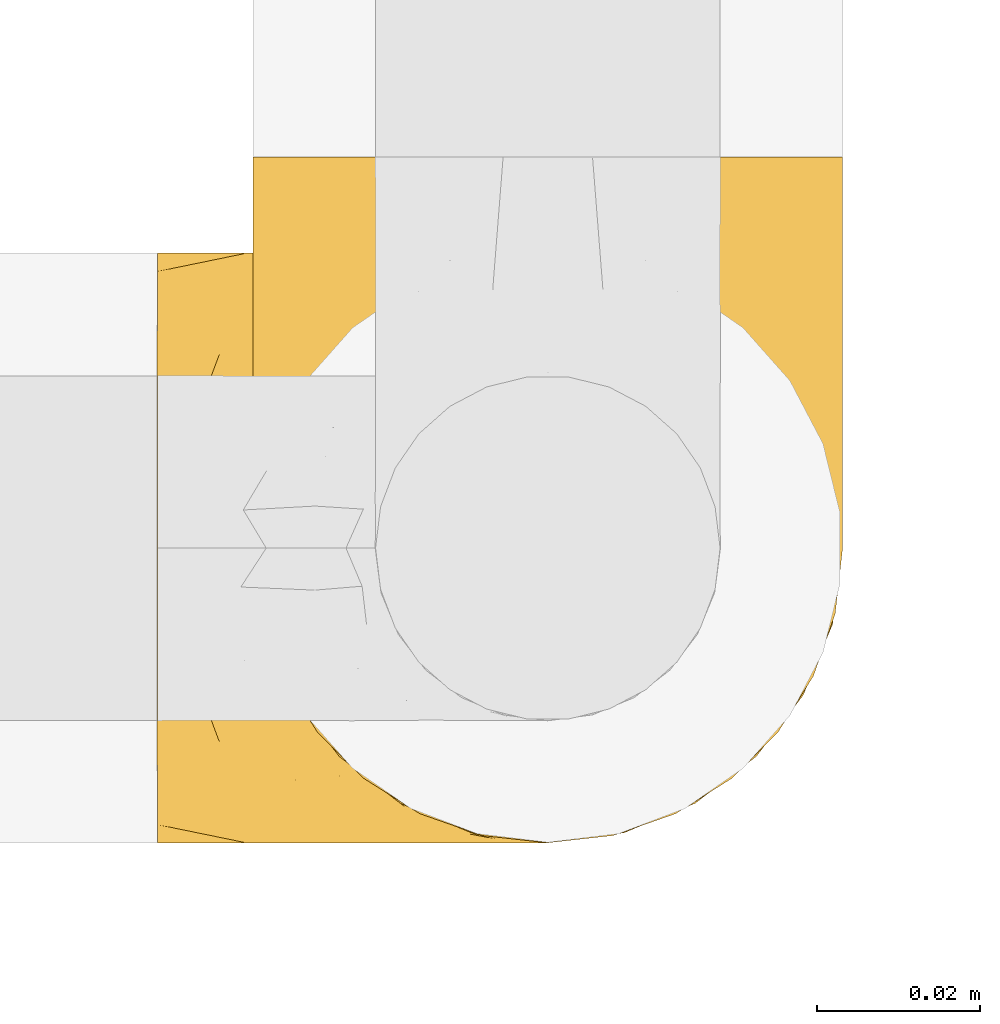
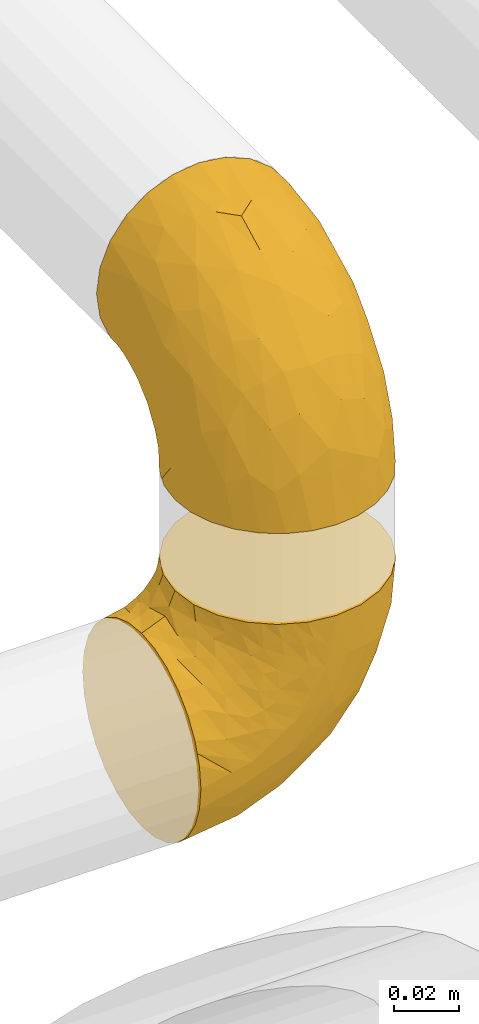
# One storey, part 17 of 39: 2 coverings.
"""IFC2X3 building model written with IfcOpenShell, lengths in millimetres."""

import ifcopenshell
import ifcopenshell.guid

model = None  # the IFC model being written
_history = None  # IfcOwnerHistory: only IFC2X3 demands one
_inside = {}  # id of a spatial element -> (the spatial element, [elements in it])
_under = {}  # id of a project, library or spatial element -> (it, [spatial elements below it])
_declared = {}  # id of a project -> (the project, [libraries it declares])
_typed = {}  # id of a type object -> (the type object, [elements of that type])
_made_of = {}  # id of a material, layer set ... -> (it, [elements and type objects made of it])


def new_model(schema):
    """Start an empty IFC model of exactly this schema.

    Asked for "IFC4X3", IfcOpenShell would pick the latest addendum, in which some entities
    have other attributes; the version numbers below select the first issue.
    IFC2X3 requires an IfcOwnerHistory on every rooted entity: one is made here for all.
    """
    global model, _history
    if schema == "IFC4X3":
        model = ifcopenshell.file(schema_version=(4, 3, 0, 0))
    else:
        model = ifcopenshell.file(schema=schema)
    _inside.clear()
    _under.clear()
    _declared.clear()
    _typed.clear()
    _made_of.clear()
    _history = None
    if model.schema == "IFC2X3":
        org = make("IfcOrganization", Name="unknown")
        user = make(
            "IfcPersonAndOrganization",
            ThePerson=make("IfcPerson", FamilyName="unknown"),
            TheOrganization=org,
        )
        app = make(
            "IfcApplication",
            ApplicationDeveloper=org,
            Version="unknown",
            ApplicationFullName="unknown",
            ApplicationIdentifier="unknown",
        )
        _history = make(
            "IfcOwnerHistory",
            OwningUser=user,
            OwningApplication=app,
            ChangeAction="ADDED",
            CreationDate=0,
        )
    return model


def make(cls, **values):
    """One entity of the class cls with the attributes given. An attribute that is None is left unset."""
    return model.create_entity(
        cls, **{name: value for name, value in values.items() if value is not None}
    )


def entity(cls, *values):
    """Any entity or typed value of the class cls, its attributes in the order of the schema. None: left unset."""
    e = model.create_entity(cls)
    for i, value in enumerate(values):
        if value is not None:
            e[i] = value
    return e


def rooted(cls, **values):
    """An entity with a GlobalId (a new one), such as an element, a storey or a relation."""
    return make(cls, GlobalId=ifcopenshell.guid.new(), OwnerHistory=_history, **values)


def si_unit(unit_type, name, prefix=None):
    """IfcSIUnit, for example si_unit("LENGTHUNIT", "METRE", prefix="MILLI")."""
    return make("IfcSIUnit", UnitType=unit_type, Prefix=prefix, Name=name)


def converted_unit(unit_type, name, factor, base, dimensions=None, offset=None):
    """IfcConversionBasedUnit, such as the inch: factor (a typed value) times the base unit."""
    return make(
        "IfcConversionBasedUnit"
        if offset is None
        else "IfcConversionBasedUnitWithOffset",
        ConversionOffset=offset,
        Dimensions=None
        if dimensions is None
        else entity("IfcDimensionalExponents", *dimensions),
        UnitType=unit_type,
        Name=name,
        ConversionFactor=make(
            "IfcMeasureWithUnit", ValueComponent=factor, UnitComponent=base
        ),
    )


def derived_unit(unit_type, elements):
    """IfcDerivedUnit: a product of units, each with its exponent."""
    return make(
        "IfcDerivedUnit",
        Elements=[
            make("IfcDerivedUnitElement", Unit=unit, Exponent=power)
            for unit, power in elements
        ],
        UnitType=unit_type,
    )


def assignment(units):
    """IfcUnitAssignment: the units of a project."""
    return None if units is None else make("IfcUnitAssignment", Units=units)


def point(xyz):
    """IfcCartesianPoint."""
    return None if xyz is None else make("IfcCartesianPoint", Coordinates=xyz)


def direction(xyz):
    """IfcDirection."""
    return None if xyz is None else make("IfcDirection", DirectionRatios=xyz)


def frame(location, z_axis=None, x_axis=None):
    """IfcAxis2Placement3D, a coordinate frame: its origin and axes. An axis left out is left unset."""
    return make(
        "IfcAxis2Placement3D",
        Location=point(location),
        Axis=direction(z_axis),
        RefDirection=direction(x_axis),
    )


def origin():
    """The frame at (0, 0, 0) with its axes left unset."""
    return frame((0.0, 0.0, 0.0))


def place(relative_to, where):
    """IfcLocalPlacement: puts the frame where relative to a parent placement (None: the world)."""
    return make(
        "IfcLocalPlacement", PlacementRelTo=relative_to, RelativePlacement=where
    )


def context(
    kind, dimensions, precision=None, world=None, true_north=None, identifier=None
):
    """IfcGeometricRepresentationContext, for example the 3D "Model" context."""
    return make(
        "IfcGeometricRepresentationContext",
        ContextIdentifier=identifier,
        ContextType=kind,
        CoordinateSpaceDimension=dimensions,
        Precision=precision,
        WorldCoordinateSystem=world,
        TrueNorth=true_north,
    )


def subcontext(parent, identifier, kind, view, scale=None):
    """IfcGeometricRepresentationSubContext, for example "Body" below "Model"."""
    return make(
        "IfcGeometricRepresentationSubContext",
        ContextIdentifier=identifier,
        ContextType=kind,
        ParentContext=parent,
        TargetScale=scale,
        TargetView=view,
    )


def project(units=None, contexts=None):
    """IfcProject with its units and contexts."""
    return rooted(
        "IfcProject",
        Name="project",
        RepresentationContexts=contexts,
        UnitsInContext=assignment(units),
    )


def spatial(cls, under=None, at=None, **own):
    """A site, building, storey or space (cls), placed at a placement, below another one or the project."""
    s = rooted(cls, ObjectPlacement=at, **own)
    if under is not None:
        _under.setdefault(under.id(), (under, []))[1].append(s)
    return s


def faces_of(points, faces, orient=None, outer=None):
    """IfcFace entities. A face is a list of loops; a loop is a list of indices into points, from 0.

    orient and outer hold one flag for each loop. By default every Orientation is true, the
    first loop of a face is its IfcFaceOuterBound and the others are IfcFaceBound.
    """
    made = []
    for i, loops in enumerate(faces):
        bounds = []
        for j, loop in enumerate(loops):
            is_outer = j == 0 if outer is None else outer[i][j]
            bounds.append(
                make(
                    "IfcFaceOuterBound" if is_outer else "IfcFaceBound",
                    Bound=make("IfcPolyLoop", Polygon=[points[k] for k in loop]),
                    Orientation=True if orient is None else orient[i][j],
                )
            )
        made.append(make("IfcFace", Bounds=bounds))
    return made


def faceted_brep(points, faces, orient=None, outer=None, voids=None):
    """IfcFacetedBrep: a solid bounded by flat faces; with voids (closed shells), ...WithVoids."""
    shared = [point(p) for p in points]
    hull = make("IfcClosedShell", CfsFaces=faces_of(shared, faces, orient, outer))
    if voids is None:
        return make("IfcFacetedBrep", Outer=hull)
    return make(
        "IfcFacetedBrepWithVoids",
        Outer=hull,
        Voids=[
            make(cls, CfsFaces=faces_of(shared, fs, o, b)) for cls, fs, o, b in voids
        ],
    )


def shape(context_of_items, identifier, shape_type, items):
    """IfcShapeRepresentation: the items that make up one representation, for example the "Body"."""
    return make(
        "IfcShapeRepresentation",
        ContextOfItems=context_of_items,
        RepresentationIdentifier=identifier,
        RepresentationType=shape_type,
        Items=items,
    )


def made_of(thing, what):
    """Note that an element or type object is made of a material, layer set ...; save() writes the relation."""
    if what is not None:
        _made_of.setdefault(what.id(), (what, []))[1].append(thing)
    return thing


def element(
    cls,
    number,
    at=None,
    inside=None,
    cuts=None,
    type_object=None,
    material=None,
    context=None,
    identifier="Body",
    shape_type=None,
    held_by="IfcProductDefinitionShape",
    body=None,
    shapes=None,
    **own,
):
    """One element of the class cls, such as IfcWall. Its Tag is "e" and its number.

    at: its placement. inside: the storey or other place that contains it. cuts: it is an
    opening in that element (IfcRelVoidsElement). A single representation is given by context,
    identifier, shape_type and body (its items); several are given by shapes. held_by: the class
    of the entity that holds the representations. save() writes the other relations.
    """
    e = rooted(cls, Tag="e%d" % number, ObjectPlacement=at, **own)
    if body is not None:
        shapes = [shape(context, identifier, shape_type, body)]
    if shapes is not None:
        e.Representation = make(held_by, Representations=shapes)
    if inside is not None:
        _inside.setdefault(inside.id(), (inside, []))[1].append(e)
    if cuts is not None:
        rooted(
            "IfcRelVoidsElement", RelatingBuildingElement=cuts, RelatedOpeningElement=e
        )
    if type_object is not None:
        _typed.setdefault(type_object.id(), (type_object, []))[1].append(e)
    return made_of(e, material)


def aggregate(whole, parts):
    """IfcRelAggregates: a whole, such as a stair, and the parts it consists of."""
    return rooted("IfcRelAggregates", RelatingObject=whole, RelatedObjects=parts)


def save(model, path):
    """Write the relations noted so far, then the file.

    IfcRelAggregates (storeys below a building ...), IfcRelContainedInSpatialStructure (elements
    in a storey), IfcRelDefinesByType, IfcRelAssociatesMaterial and IfcRelDeclares: one each for
    every whole, place, type object, material and project.
    """
    for whole, parts in _under.values():
        aggregate(whole, parts)
    for where, things in _inside.values():
        rooted(
            "IfcRelContainedInSpatialStructure",
            RelatedElements=things,
            RelatingStructure=where,
        )
    for kind, things in _typed.values():
        rooted("IfcRelDefinesByType", RelatedObjects=things, RelatingType=kind)
    for what, things in _made_of.values():
        rooted("IfcRelAssociatesMaterial", RelatedObjects=things, RelatingMaterial=what)
    for by, libraries in _declared.values():
        rooted("IfcRelDeclares", RelatingContext=by, RelatedDefinitions=libraries)
    model.write(path)


model = new_model("IFC2X3")

# Units and contexts
model_context = context("Model", 3, precision=0.01, world=origin(), true_north=direction((6.12303176911189e-17, 1.0)))
body_context = subcontext(model_context, "Body", "Model", "MODEL_VIEW")
ifc_project = project(units=[si_unit("LENGTHUNIT", "METRE", prefix="MILLI"), si_unit("AREAUNIT", "SQUARE_METRE"), si_unit("VOLUMEUNIT", "CUBIC_METRE"), converted_unit("PLANEANGLEUNIT", "DEGREE", entity("IfcRatioMeasure", 0.0174532925199433), si_unit("PLANEANGLEUNIT", "RADIAN"), dimensions=[0, 0, 0, 0, 0, 0, 0]), si_unit("MASSUNIT", "GRAM", prefix="KILO"), derived_unit("MASSDENSITYUNIT", [(si_unit("MASSUNIT", "GRAM", prefix="KILO"), 1), (si_unit("LENGTHUNIT", "METRE"), -3)]), derived_unit("MOMENTOFINERTIAUNIT", [(si_unit("LENGTHUNIT", "METRE"), 4)]), si_unit("TIMEUNIT", "SECOND"), si_unit("FREQUENCYUNIT", "HERTZ"), si_unit("THERMODYNAMICTEMPERATUREUNIT", "DEGREE_CELSIUS"), derived_unit("THERMALTRANSMITTANCEUNIT", [(si_unit("MASSUNIT", "GRAM", prefix="KILO"), 1), (si_unit("THERMODYNAMICTEMPERATUREUNIT", "KELVIN"), -1), (si_unit("TIMEUNIT", "SECOND"), -3)]), derived_unit("VOLUMETRICFLOWRATEUNIT", [(si_unit("LENGTHUNIT", "METRE"), 3), (si_unit("TIMEUNIT", "SECOND"), -1)]), derived_unit("MASSFLOWRATEUNIT", [(si_unit("MASSUNIT", "GRAM", prefix="KILO"), 1), (si_unit("TIMEUNIT", "SECOND"), -1)]), derived_unit("ROTATIONALFREQUENCYUNIT", [(si_unit("TIMEUNIT", "SECOND"), -1)]), si_unit("ELECTRICCURRENTUNIT", "AMPERE"), si_unit("ELECTRICVOLTAGEUNIT", "VOLT"), si_unit("POWERUNIT", "WATT"), si_unit("FORCEUNIT", "NEWTON", prefix="KILO"), si_unit("ILLUMINANCEUNIT", "LUX"), si_unit("LUMINOUSFLUXUNIT", "LUMEN"), si_unit("LUMINOUSINTENSITYUNIT", "CANDELA"), derived_unit("USERDEFINED", [(si_unit("MASSUNIT", "GRAM", prefix="KILO"), -1), (si_unit("LENGTHUNIT", "METRE"), -2), (si_unit("TIMEUNIT", "SECOND"), 3), (si_unit("LUMINOUSFLUXUNIT", "LUMEN"), 1)]), derived_unit("LINEARVELOCITYUNIT", [(si_unit("LENGTHUNIT", "METRE"), 1), (si_unit("TIMEUNIT", "SECOND"), -1)]), si_unit("PRESSUREUNIT", "PASCAL"), derived_unit("USERDEFINED", [(si_unit("LENGTHUNIT", "METRE"), -2), (si_unit("MASSUNIT", "GRAM", prefix="KILO"), 1), (si_unit("TIMEUNIT", "SECOND"), -2)]), derived_unit("LINEARFORCEUNIT", [(si_unit("MASSUNIT", "GRAM", prefix="KILO"), 1), (si_unit("LENGTHUNIT", "METRE"), 1), (si_unit("TIMEUNIT", "SECOND"), -2), (si_unit("LENGTHUNIT", "METRE"), -1)]), derived_unit("PLANARFORCEUNIT", [(si_unit("MASSUNIT", "GRAM", prefix="KILO"), 1), (si_unit("LENGTHUNIT", "METRE"), 1), (si_unit("TIMEUNIT", "SECOND"), -2), (si_unit("LENGTHUNIT", "METRE"), -2)])], contexts=[model_context])

# Site, building, storey
site_placement = place(None, origin())
site = spatial("IfcSite", under=ifc_project, at=site_placement, CompositionType="ELEMENT")
building_placement = place(site_placement, origin())
building = spatial("IfcBuilding", under=site, at=building_placement, CompositionType="ELEMENT")
storey_placement = place(building_placement, frame((0.0, 0.0, 24000.0)))
storey = spatial("IfcBuildingStorey", under=building, at=storey_placement, Name="07", CompositionType="ELEMENT", Elevation=24000.0)

# Coverings
covering_1_placement = place(storey_placement, frame((68482.28, 1563.38, 2980.31)))
element("IfcCovering", 1, at=covering_1_placement, inside=storey, Name=":ADSK_", ObjectType=":ADSK_", PredefinedType="INSULATION", context=body_context, shape_type="Brep", body=[
    faceted_brep([(74.0, 37.8, 1.6), (73.09, 29.74, 1.6), (70.41, 22.08, 1.6), (66.09, 15.22, 1.6), (60.36, 9.49, 1.6), (53.5, 5.18, 1.6), (45.85, 2.5, 1.6), (37.8, 1.6, 1.6), (29.74, 2.5, 1.6), (22.08, 5.18, 1.6), (15.22, 9.5, 1.6), (9.49, 15.23, 1.6), (5.18, 22.09, 1.6), (2.5, 29.74, 1.6), (1.6, 37.8, 1.6), (2.19, 43.06, 1.6), (2.5, 45.85, 1.6), (3.84, 49.68, 1.6), (5.18, 53.51, 1.6), (9.5, 60.37, 1.6), (15.23, 66.1, 1.6), (22.09, 70.41, 1.6), (29.74, 73.09, 1.6), (37.8, 74.0, 1.6), (45.85, 73.09, 1.6), (53.51, 70.41, 1.6), (60.37, 66.09, 1.6), (66.1, 60.36, 1.6), (70.41, 53.5, 1.6), (71.75, 49.67, 1.6), (73.09, 45.85, 1.6), (73.4, 43.06, 1.6), (28.43, 85.79, 14.63), (19.7, 85.79, 18.25), (12.2, 85.79, 24.0), (9.32, 85.79, 27.75), (6.45, 85.79, 31.5), (4.64, 85.79, 35.86), (2.83, 85.79, 40.23), (2.29, 85.79, 44.31), (1.94, 85.79, 46.95), (1.6, 85.79, 49.6), (2.83, 85.79, 58.96), (6.45, 85.79, 67.7), (12.2, 85.79, 75.19), (19.7, 85.79, 80.95), (28.43, 85.79, 84.56), (37.8, 85.79, 85.8), (47.16, 85.79, 84.56), (55.9, 85.79, 80.95), (63.39, 85.79, 75.19), (69.15, 85.79, 67.7), (72.76, 85.79, 58.96), (74.0, 85.79, 49.6), (73.3, 85.79, 44.31), (72.76, 85.79, 40.23), (70.95, 85.79, 35.86), (69.15, 85.79, 31.5), (66.27, 85.79, 27.75), (63.39, 85.79, 24.0), (55.9, 85.79, 18.25), (47.16, 85.79, 14.63), (37.8, 85.79, 13.4), (50.11, 27.78, 59.6), (37.8, 26.99, 60.4), (46.44, 19.14, 51.31), (37.8, 59.77, 81.67), (44.03, 64.44, 82.48), (37.8, 67.99, 82.97), (47.59, 45.3, 73.87), (57.17, 53.86, 73.39), (50.38, 66.0, 81.11), (58.65, 70.91, 77.75), (73.37, 33.16, 16.46), (71.27, 49.16, 51.33), (70.16, 68.27, 63.37), (66.97, 50.63, 61.46), (73.22, 70.35, 54.83), (74.0, 67.42, 45.94), (74.0, 74.88, 47.42), (74.0, 77.6, 47.97), (74.0, 80.33, 48.51), (64.86, 65.68, 70.77), (70.93, 24.84, 15.75), (45.19, 11.5, 39.56), (48.57, 5.67, 21.48), (54.32, 13.35, 36.01), (72.94, 39.73, 34.58), (74.0, 41.45, 19.96), (74.0, 44.05, 23.86), (74.0, 46.65, 27.75), (74.0, 49.25, 31.64), (74.0, 51.85, 35.54), (68.72, 35.98, 46.13), (73.34, 57.18, 48.41), (67.28, 18.48, 16.74), (61.7, 13.36, 21.75), (55.94, 7.85, 16.31), (37.8, 4.41, 19.4), (53.02, 20.15, 48.77), (57.31, 31.91, 58.66), (74.0, 38.88, 7.05), (74.0, 39.97, 12.51), (64.86, 21.9, 34.87), (59.15, 22.4, 45.71), (70.05, 28.44, 30.95), (55.99, 41.69, 67.49), (37.8, 48.04, 75.69), (63.54, 33.67, 53.34), (61.41, 44.49, 64.72), (37.8, 5.72, 27.61), (37.8, 17.67, 51.08), (37.8, 11.7, 39.35), (74.0, 55.75, 38.14), (74.0, 59.64, 40.74), (74.0, 63.53, 43.34), (37.8, 36.3, 69.71), (70.9, 69.92, 30.92), (69.2, 69.03, 26.47), (65.83, 74.68, 24.1), (73.31, 79.54, 42.08), (67.07, 79.54, 27.56), (62.53, 81.25, 22.68), (52.3, 76.19, 12.9), (54.94, 72.4, 10.56), (46.54, 75.54, 9.38), (72.08, 63.7, 30.49), (73.17, 66.91, 37.21), (59.32, 72.9, 15.4), (56.36, 77.88, 16.56), (48.99, 80.79, 14.21), (58.36, 80.78, 19.1), (66.05, 60.93, 6.65), (61.56, 66.56, 9.22), (68.98, 58.7, 13.56), (73.26, 46.01, 10.42), (70.05, 80.23, 32.67), (73.39, 70.42, 40.02), (70.87, 74.75, 33.0), (61.17, 68.99, 13.09), (71.9, 51.42, 11.85), (65.19, 71.01, 20.93), (37.8, 76.08, 6.64), (46.04, 73.72, 5.68), (52.15, 71.61, 5.7), (66.57, 63.33, 14.76), (37.8, 77.45, 9.94), (73.34, 52.09, 25.2), (72.91, 50.98, 19.66), (37.8, 80.75, 11.31), (72.75, 76.87, 39.13), (70.14, 63.89, 24.56), (72.14, 57.77, 25.08), (66.28, 66.53, 18.54), (73.22, 57.73, 30.86), (17.23, 80.78, 19.1), (26.6, 80.8, 14.22), (13.06, 81.26, 22.68), (1.6, 38.88, 7.05), (1.6, 39.97, 12.51), (29.56, 73.72, 5.68), (20.66, 72.41, 10.56), (23.45, 71.61, 5.7), (14.05, 66.57, 9.22), (1.6, 83.06, 49.05), (1.6, 74.88, 47.42), (1.6, 80.33, 48.51), (19.23, 77.88, 16.56), (23.3, 76.2, 12.9), (16.29, 72.91, 15.39), (8.09, 77.2, 27.52), (4.72, 74.75, 33.0), (5.54, 80.23, 32.67), (3.69, 51.43, 11.86), (2.84, 76.87, 39.13), (2.42, 66.91, 37.21), (4.69, 69.92, 30.92), (3.52, 63.71, 30.49), (2.2, 70.42, 40.02), (29.05, 75.54, 9.38), (2.29, 79.54, 42.08), (9.55, 60.94, 6.65), (14.43, 69.0, 13.09), (2.33, 46.02, 10.43), (9.32, 66.54, 18.54), (3.45, 57.77, 25.07), (5.45, 63.89, 24.56), (10.41, 71.03, 20.93), (2.81, 51.53, 19.57), (6.62, 58.72, 13.56), (1.6, 41.45, 19.96), (9.76, 74.69, 24.09), (9.03, 63.35, 14.76), (2.37, 57.73, 30.85), (4.15, 56.44, 20.0), (2.17, 51.59, 25.27), (1.6, 44.05, 23.86), (1.6, 59.64, 40.74), (1.6, 55.75, 38.14), (1.6, 67.42, 45.94), (1.6, 63.53, 43.34), (6.39, 69.03, 26.46), (1.6, 46.65, 27.75), (1.6, 51.85, 35.54), (1.6, 49.25, 31.64), (4.32, 49.16, 51.33), (2.37, 70.35, 54.83), (2.25, 57.18, 48.41), (16.43, 22.41, 45.7), (18.27, 31.92, 58.67), (12.04, 33.68, 53.34), (8.62, 50.62, 61.45), (6.87, 35.99, 46.13), (10.72, 21.91, 34.86), (2.64, 39.73, 34.58), (25.48, 27.78, 59.6), (19.59, 41.7, 67.49), (5.43, 68.27, 63.37), (31.57, 64.44, 82.48), (25.21, 66.0, 81.11), (5.53, 28.45, 30.94), (16.94, 70.91, 77.75), (10.73, 65.67, 70.76), (18.42, 53.85, 73.39), (21.26, 13.35, 36.01), (27.01, 5.67, 21.48), (30.39, 11.5, 39.57), (2.22, 33.16, 16.45), (13.88, 13.37, 21.75), (8.3, 18.49, 16.74), (28.0, 45.3, 73.87), (29.14, 19.14, 51.31), (22.56, 20.15, 48.77), (19.64, 7.85, 16.32), (14.18, 44.48, 64.71), (4.66, 24.85, 15.75)], [[[0, 1, 2, 3, 4, 5, 6, 7, 8, 9, 10, 11, 12, 13, 14, 15, 16, 17, 18, 19, 20, 21, 22, 23, 24, 25, 26, 27, 28, 29, 30, 31]], [[32, 33, 34, 35, 36, 37, 38, 39, 40, 41, 42, 43, 44, 45, 46, 47, 48, 49, 50, 51, 52, 53, 54, 55, 56, 57, 58, 59, 60, 61, 62]], [[63, 64, 65]], [[66, 67, 68]], [[69, 70, 71]], [[71, 70, 72]], [[73, 1, 0]], [[74, 75, 76]], [[49, 48, 71]], [[77, 78, 79, 80, 81, 53]], [[50, 82, 51]], [[72, 50, 49]], [[2, 1, 83]], [[84, 85, 86]], [[87, 88, 89, 90, 91, 92]], [[53, 52, 77]], [[93, 74, 76]], [[5, 85, 6]], [[94, 78, 77]], [[95, 3, 2]], [[95, 96, 3]], [[75, 51, 82]], [[85, 5, 97]], [[50, 72, 82]], [[97, 5, 4]], [[85, 98, 6]], [[94, 87, 92]], [[74, 77, 75]], [[99, 100, 63]], [[96, 4, 3]], [[73, 0, 101, 102, 88]], [[96, 103, 104]], [[48, 68, 67]], [[84, 99, 65]], [[105, 83, 73]], [[105, 95, 83]], [[100, 106, 63]], [[86, 96, 104]], [[97, 86, 85]], [[67, 107, 69]], [[100, 108, 109]], [[84, 110, 85]], [[93, 87, 74]], [[96, 95, 103]], [[69, 71, 67]], [[70, 69, 106]], [[4, 96, 97]], [[86, 97, 96]], [[83, 95, 2]], [[103, 95, 105]], [[93, 103, 105]], [[103, 108, 104]], [[75, 77, 52]], [[94, 77, 74]], [[51, 75, 52]], [[75, 82, 76]], [[109, 82, 70]], [[93, 76, 108]], [[88, 87, 73]], [[105, 73, 87]], [[84, 86, 99]], [[84, 111, 112, 110]], [[98, 85, 110]], [[98, 7, 6]], [[73, 83, 1]], [[71, 72, 49]], [[82, 72, 70]], [[87, 94, 74]], [[94, 92, 113, 114, 115, 78]], [[48, 47, 68]], [[48, 67, 71]], [[100, 104, 108]], [[99, 86, 104]], [[109, 108, 76]], [[100, 109, 106]], [[82, 109, 76]], [[106, 109, 70]], [[100, 99, 104]], [[99, 63, 65]], [[69, 116, 63]], [[111, 84, 65]], [[64, 63, 116]], [[64, 111, 65]], [[63, 106, 69]], [[103, 93, 108]], [[87, 93, 105]], [[107, 67, 66]], [[107, 116, 69]], [[117, 118, 119]], [[80, 120, 55]], [[121, 119, 122]], [[120, 56, 55]], [[123, 124, 125]], [[114, 126, 127]], [[101, 0, 31, 30, 102]], [[123, 128, 124]], [[129, 123, 130]], [[60, 122, 131]], [[132, 133, 134]], [[29, 28, 135]], [[131, 61, 60]], [[122, 60, 59]], [[136, 137, 138]], [[124, 128, 139]], [[132, 27, 26]], [[131, 130, 61]], [[140, 135, 28]], [[102, 29, 135]], [[119, 118, 141]], [[58, 136, 121]], [[140, 28, 27]], [[54, 53, 81, 80, 55]], [[23, 142, 143]], [[24, 144, 25]], [[25, 144, 133]], [[26, 25, 133]], [[134, 133, 145]], [[125, 142, 146]], [[124, 143, 125]], [[147, 90, 148]], [[124, 144, 143]], [[149, 125, 146]], [[150, 57, 56]], [[137, 78, 115]], [[130, 62, 61]], [[132, 140, 27]], [[151, 152, 153]], [[140, 134, 148]], [[148, 89, 140]], [[120, 78, 150]], [[115, 127, 137]], [[150, 137, 136]], [[78, 120, 80, 79]], [[150, 56, 120]], [[91, 154, 92]], [[127, 117, 138]], [[144, 24, 143]], [[133, 144, 124]], [[152, 91, 147]], [[145, 152, 134]], [[23, 143, 24]], [[142, 125, 143]], [[130, 125, 149]], [[128, 123, 129]], [[125, 130, 123]], [[62, 130, 149]], [[141, 129, 119]], [[124, 139, 133]], [[128, 153, 139]], [[145, 139, 153]], [[92, 154, 113]], [[127, 115, 114]], [[117, 127, 126]], [[118, 117, 126]], [[121, 117, 119]], [[138, 137, 127]], [[78, 137, 150]], [[151, 118, 126]], [[118, 151, 141]], [[153, 128, 141]], [[129, 141, 128]], [[102, 30, 29]], [[140, 88, 135]], [[88, 102, 135]], [[133, 132, 26]], [[140, 132, 134]], [[121, 122, 59]], [[131, 119, 129]], [[121, 59, 58]], [[121, 138, 117]], [[121, 136, 138]], [[57, 150, 136]], [[58, 57, 136]], [[119, 131, 122]], [[131, 129, 130]], [[139, 145, 133]], [[152, 145, 153]], [[89, 148, 90]], [[89, 88, 140]], [[147, 134, 152]], [[134, 147, 148]], [[126, 114, 113]], [[152, 154, 91]], [[91, 90, 147]], [[151, 153, 141]], [[154, 151, 126]], [[151, 154, 152]], [[113, 154, 126]], [[155, 32, 156]], [[33, 157, 34]], [[62, 149, 156]], [[15, 14, 158, 159, 16]], [[160, 23, 22]], [[161, 162, 163]], [[164, 41, 40, 39, 38, 165, 166]], [[167, 168, 169]], [[157, 170, 34]], [[171, 172, 170]], [[18, 173, 19]], [[174, 37, 36]], [[175, 176, 177]], [[178, 171, 175]], [[146, 179, 149]], [[168, 179, 161]], [[161, 160, 162]], [[162, 160, 22]], [[38, 37, 180]], [[20, 19, 181]], [[21, 20, 163]], [[161, 182, 169]], [[18, 183, 173]], [[184, 185, 186]], [[169, 187, 167]], [[188, 189, 173]], [[159, 190, 183]], [[17, 159, 183]], [[156, 179, 168]], [[191, 157, 155]], [[192, 163, 189]], [[21, 162, 22]], [[146, 142, 179]], [[181, 163, 20]], [[177, 186, 193]], [[178, 172, 171]], [[167, 156, 168]], [[185, 194, 195]], [[181, 173, 189]], [[173, 196, 188]], [[197, 177, 198]], [[199, 165, 180]], [[180, 165, 38]], [[200, 178, 175]], [[37, 174, 180]], [[199, 180, 174]], [[175, 197, 200]], [[177, 176, 201]], [[163, 162, 21]], [[160, 161, 179]], [[192, 185, 184]], [[194, 189, 188]], [[179, 142, 160]], [[23, 160, 142]], [[169, 168, 161]], [[155, 156, 167]], [[182, 161, 163]], [[184, 186, 187]], [[62, 156, 32]], [[179, 156, 149]], [[192, 182, 163]], [[184, 169, 182]], [[176, 175, 171]], [[174, 178, 199]], [[197, 175, 177]], [[170, 176, 171]], [[201, 176, 191]], [[199, 178, 200]], [[178, 174, 172]], [[187, 201, 191]], [[201, 187, 186]], [[167, 187, 191]], [[169, 184, 187]], [[173, 183, 190]], [[17, 16, 159]], [[173, 181, 19]], [[163, 181, 189]], [[155, 157, 33]], [[170, 157, 191]], [[176, 170, 191]], [[35, 170, 172]], [[35, 172, 36]], [[34, 170, 35]], [[174, 36, 172]], [[32, 155, 33]], [[191, 155, 167]], [[192, 189, 194]], [[182, 192, 184]], [[193, 198, 177]], [[183, 18, 17]], [[196, 173, 190]], [[196, 202, 188]], [[193, 186, 185]], [[201, 186, 177]], [[188, 195, 194]], [[203, 193, 204]], [[188, 202, 195]], [[192, 194, 185]], [[202, 204, 195]], [[185, 195, 204]], [[204, 193, 185]], [[198, 193, 203]], [[205, 206, 207]], [[208, 209, 210]], [[210, 211, 212]], [[210, 213, 208]], [[214, 203, 204, 202, 196, 190]], [[206, 41, 164, 166, 165, 199]], [[215, 216, 209]], [[206, 217, 42]], [[218, 46, 219]], [[207, 214, 205]], [[212, 214, 220]], [[221, 219, 45]], [[45, 219, 46]], [[221, 222, 223]], [[224, 225, 226]], [[222, 44, 43]], [[222, 217, 211]], [[220, 214, 227]], [[227, 190, 159, 158, 14]], [[217, 43, 42]], [[14, 13, 227]], [[225, 9, 8]], [[10, 228, 11]], [[11, 229, 12]], [[208, 213, 228]], [[228, 229, 11]], [[230, 219, 223]], [[231, 232, 226]], [[231, 64, 215]], [[225, 233, 9]], [[229, 213, 220]], [[233, 10, 9]], [[110, 225, 98]], [[41, 206, 42]], [[222, 211, 234]], [[224, 228, 233]], [[225, 8, 98]], [[221, 45, 44]], [[226, 110, 112, 111]], [[12, 229, 235]], [[46, 218, 68]], [[230, 107, 218]], [[223, 234, 216]], [[107, 66, 218]], [[224, 233, 225]], [[228, 10, 233]], [[213, 229, 228]], [[235, 229, 220]], [[208, 228, 224]], [[212, 213, 210]], [[207, 206, 199]], [[205, 211, 217]], [[205, 217, 206]], [[43, 217, 222]], [[212, 211, 205]], [[210, 209, 234]], [[227, 13, 235]], [[214, 190, 227]], [[110, 226, 225]], [[232, 231, 215]], [[8, 7, 98]], [[227, 235, 220]], [[13, 12, 235]], [[222, 221, 44]], [[219, 221, 223]], [[207, 199, 200, 197, 198, 203]], [[214, 207, 203]], [[68, 218, 66]], [[68, 47, 46]], [[230, 218, 219]], [[224, 232, 208]], [[208, 232, 209]], [[216, 215, 230]], [[210, 234, 211]], [[216, 234, 209]], [[222, 234, 223]], [[226, 232, 224]], [[209, 232, 215]], [[226, 111, 231]], [[64, 116, 215]], [[231, 111, 64]], [[116, 230, 215]], [[230, 223, 216]], [[214, 212, 205]], [[213, 212, 220]], [[230, 116, 107]]]),
])
covering_2_placement = place(storey_placement, frame((68470.51, 1563.38, 2862.25)))
element("IfcCovering", 2, at=covering_2_placement, inside=storey, Name=":ADSK_", ObjectType=":ADSK_", PredefinedType="INSULATION", context=body_context, shape_type="Brep", body=[
    faceted_brep([(1.6, 45.85, 73.09), (1.6, 53.51, 70.41), (1.61, 60.37, 66.09), (1.62, 66.1, 60.36), (1.64, 70.41, 53.5), (1.64, 71.75, 49.67), (1.65, 73.09, 45.85), (1.66, 73.4, 43.06), (1.67, 74.0, 37.8), (1.68, 73.09, 29.74), (1.7, 70.41, 22.08), (1.71, 66.09, 15.22), (1.72, 60.36, 9.49), (1.73, 53.5, 5.18), (1.74, 45.85, 2.5), (1.74, 37.8, 1.6), (1.74, 29.74, 2.5), (1.73, 22.08, 5.18), (1.72, 15.22, 9.5), (1.71, 9.49, 15.23), (1.7, 5.18, 22.09), (1.68, 2.5, 29.74), (1.67, 1.6, 37.8), (1.66, 2.19, 43.06), (1.65, 2.5, 45.85), (1.64, 3.84, 49.68), (1.64, 5.18, 53.51), (1.62, 9.5, 60.37), (1.61, 15.23, 66.1), (1.6, 22.09, 70.41), (1.6, 29.74, 73.09), (1.6, 37.8, 74.0), (14.61, 28.43, 85.8), (18.22, 19.7, 85.8), (23.97, 12.2, 85.8), (27.72, 9.32, 85.8), (31.47, 6.45, 85.8), (35.84, 4.64, 85.8), (40.2, 2.83, 85.8), (44.28, 2.29, 85.8), (46.93, 1.94, 85.8), (49.57, 1.6, 85.8), (58.94, 2.83, 85.8), (67.67, 6.45, 85.8), (75.17, 12.2, 85.8), (80.92, 19.7, 85.8), (84.54, 28.43, 85.8), (85.77, 37.8, 85.8), (84.54, 47.16, 85.8), (80.92, 55.9, 85.8), (75.17, 63.39, 85.8), (67.67, 69.15, 85.8), (58.94, 72.76, 85.8), (49.57, 74.0, 85.8), (44.28, 73.3, 85.8), (40.2, 72.76, 85.8), (35.84, 70.95, 85.8), (31.47, 69.15, 85.8), (27.72, 66.27, 85.8), (23.97, 63.39, 85.8), (18.22, 55.9, 85.8), (14.61, 47.16, 85.8), (13.37, 37.8, 85.8), (59.65, 50.1, 27.84), (60.44, 37.8, 27.05), (51.35, 46.47, 19.2), (81.66, 37.8, 59.81), (82.47, 44.03, 64.47), (82.96, 37.8, 67.99), (73.85, 47.6, 45.31), (73.38, 57.17, 53.89), (81.09, 50.38, 66.02), (77.72, 58.65, 70.94), (16.51, 73.37, 33.19), (51.34, 71.27, 49.2), (63.34, 70.17, 68.28), (61.44, 66.97, 50.65), (54.81, 73.23, 70.38), (45.93, 74.0, 67.45), (47.4, 74.0, 74.88), (47.95, 74.0, 77.61), (48.49, 74.0, 80.34), (70.74, 64.87, 65.69), (15.84, 70.93, 24.86), (39.67, 45.21, 11.57), (21.61, 48.57, 5.7), (36.11, 54.32, 13.41), (34.61, 72.95, 39.77), (20.01, 74.0, 41.48), (23.89, 74.0, 44.08), (27.78, 74.0, 46.68), (31.66, 74.0, 49.29), (35.55, 74.0, 51.89), (46.16, 68.72, 36.04), (48.4, 73.34, 57.21), (16.85, 67.28, 18.51), (21.86, 61.7, 13.4), (16.44, 55.94, 7.88), (19.54, 37.8, 4.45), (48.85, 53.03, 20.22), (58.76, 57.31, 32.04), (7.12, 74.0, 38.89), (12.58, 74.0, 39.99), (34.98, 64.86, 21.97), (45.79, 59.15, 22.48), (31.0, 70.06, 28.49), (67.5, 56.07, 41.82), (75.7, 37.8, 48.08), (53.36, 63.55, 33.73), (64.69, 61.44, 44.52), (27.72, 37.8, 5.76), (51.14, 37.8, 17.74), (39.43, 37.8, 11.75), (38.14, 74.0, 55.78), (40.74, 74.0, 59.67), (43.33, 74.0, 63.56), (69.73, 37.8, 36.36), (30.92, 70.9, 69.93), (26.45, 69.19, 69.07), (24.07, 65.81, 74.72), (42.06, 73.3, 79.55), (27.53, 67.07, 79.55), (22.65, 62.52, 81.27), (12.88, 52.28, 76.21), (10.57, 54.94, 72.42), (9.37, 46.54, 75.55), (39.11, 72.75, 76.87), (15.37, 59.27, 72.94), (16.53, 56.35, 77.89), (14.2, 48.99, 80.81), (19.07, 58.35, 80.79), (6.68, 66.05, 60.94), (9.23, 61.55, 66.58), (13.58, 68.98, 58.73), (10.47, 73.26, 46.04), (32.65, 70.05, 80.24), (40.01, 73.39, 70.43), (32.97, 70.87, 74.77), (13.1, 61.17, 69.01), (11.9, 71.9, 51.44), (20.92, 65.18, 71.05), (6.63, 37.8, 76.09), (5.67, 46.04, 73.72), (5.71, 52.15, 71.62), (14.77, 66.56, 63.37), (9.92, 37.8, 77.46), (25.22, 73.34, 52.11), (19.7, 72.92, 51.0), (11.29, 37.8, 80.75), (24.56, 70.14, 63.9), (25.07, 72.14, 57.78), (18.55, 66.27, 66.56), (30.47, 72.07, 63.74), (37.2, 73.17, 66.94), (28.88, 72.52, 59.68), (19.07, 17.24, 80.79), (14.2, 26.59, 80.81), (22.65, 13.08, 81.28), (7.12, 1.6, 38.89), (12.58, 1.6, 39.99), (5.67, 29.56, 73.72), (10.57, 20.66, 72.43), (5.71, 23.45, 71.62), (9.23, 14.05, 66.59), (47.4, 1.6, 74.88), (48.49, 1.6, 80.34), (49.03, 1.6, 83.07), (16.53, 19.24, 77.9), (12.88, 23.32, 76.22), (15.36, 16.35, 72.96), (27.49, 8.1, 77.24), (32.97, 4.72, 74.77), (32.65, 5.54, 80.24), (11.91, 3.69, 51.45), (39.11, 2.84, 76.87), (37.2, 2.42, 66.94), (30.92, 4.69, 69.94), (30.47, 3.52, 63.75), (40.01, 2.2, 70.43), (9.37, 29.06, 75.56), (42.06, 2.29, 79.55), (6.68, 9.55, 60.95), (13.1, 14.43, 69.02), (10.47, 2.33, 46.04), (24.56, 5.45, 63.89), (28.89, 3.06, 59.67), (20.92, 10.41, 71.06), (19.6, 2.81, 51.57), (13.58, 6.62, 58.74), (20.01, 1.6, 41.48), (24.06, 9.78, 74.72), (14.77, 9.04, 63.38), (25.06, 3.45, 57.79), (35.55, 1.6, 51.89), (23.89, 1.6, 44.08), (40.74, 1.6, 59.67), (38.14, 1.6, 55.78), (18.55, 9.33, 66.58), (45.93, 1.6, 67.45), (43.33, 1.6, 63.56), (26.44, 6.4, 69.07), (20.0, 4.16, 56.48), (27.78, 1.6, 46.68), (25.32, 2.17, 51.64), (31.66, 1.6, 49.29), (51.33, 4.31, 49.21), (54.81, 2.36, 70.38), (48.4, 2.25, 57.22), (45.78, 16.43, 22.48), (58.77, 18.27, 32.05), (53.36, 12.03, 33.74), (61.44, 8.62, 50.64), (46.15, 6.86, 36.05), (34.97, 10.72, 21.98), (34.6, 2.64, 39.78), (59.64, 25.49, 27.84), (67.49, 19.5, 41.82), (63.34, 5.42, 68.28), (82.47, 31.56, 64.47), (81.09, 25.21, 66.01), (31.0, 5.53, 28.5), (77.72, 16.94, 70.93), (70.74, 10.72, 65.69), (73.38, 18.42, 53.88), (36.11, 21.26, 13.41), (21.61, 27.01, 5.71), (39.68, 30.38, 11.57), (16.51, 2.22, 33.19), (21.86, 13.88, 13.41), (16.85, 8.3, 18.52), (73.85, 27.99, 45.31), (51.35, 29.1, 19.2), (48.85, 22.55, 20.23), (16.45, 19.64, 7.88), (64.67, 14.14, 44.51), (15.84, 4.66, 24.87)], [[[0, 1, 2, 3, 4, 5, 6, 7, 8, 9, 10, 11, 12, 13, 14, 15, 16, 17, 18, 19, 20, 21, 22, 23, 24, 25, 26, 27, 28, 29, 30, 31]], [[32, 33, 34, 35, 36, 37, 38, 39, 40, 41, 42, 43, 44, 45, 46, 47, 48, 49, 50, 51, 52, 53, 54, 55, 56, 57, 58, 59, 60, 61, 62]], [[63, 64, 65]], [[66, 67, 68]], [[69, 70, 71]], [[71, 70, 72]], [[73, 9, 8]], [[74, 75, 76]], [[49, 48, 71]], [[77, 78, 79, 80, 81, 53]], [[50, 82, 51]], [[72, 50, 49]], [[10, 9, 83]], [[84, 85, 86]], [[87, 88, 89, 90, 91, 92]], [[53, 52, 77]], [[93, 74, 76]], [[13, 85, 14]], [[94, 78, 77]], [[95, 11, 10]], [[95, 96, 11]], [[75, 51, 82]], [[85, 13, 97]], [[50, 72, 82]], [[97, 13, 12]], [[85, 98, 14]], [[94, 87, 92]], [[74, 77, 75]], [[99, 100, 63]], [[96, 12, 11]], [[73, 8, 101, 102, 88]], [[96, 103, 104]], [[48, 68, 67]], [[84, 99, 65]], [[105, 83, 73]], [[105, 95, 83]], [[100, 106, 63]], [[86, 96, 104]], [[97, 86, 85]], [[67, 107, 69]], [[100, 108, 109]], [[84, 110, 85]], [[93, 87, 74]], [[96, 95, 103]], [[69, 71, 67]], [[70, 69, 106]], [[12, 96, 97]], [[86, 97, 96]], [[83, 95, 10]], [[103, 95, 105]], [[93, 103, 105]], [[103, 108, 104]], [[75, 77, 52]], [[94, 77, 74]], [[51, 75, 52]], [[75, 82, 76]], [[109, 82, 70]], [[93, 76, 108]], [[88, 87, 73]], [[105, 73, 87]], [[84, 86, 99]], [[84, 111, 112, 110]], [[98, 85, 110]], [[98, 15, 14]], [[73, 83, 9]], [[71, 72, 49]], [[82, 72, 70]], [[87, 94, 74]], [[94, 92, 113, 114, 115, 78]], [[48, 47, 68]], [[48, 67, 71]], [[100, 104, 108]], [[99, 86, 104]], [[109, 108, 76]], [[100, 109, 106]], [[82, 109, 76]], [[106, 109, 70]], [[100, 99, 104]], [[99, 63, 65]], [[69, 116, 63]], [[111, 84, 65]], [[64, 63, 116]], [[64, 111, 65]], [[63, 106, 69]], [[103, 93, 108]], [[87, 93, 105]], [[107, 67, 66]], [[107, 116, 69]], [[117, 118, 119]], [[80, 120, 55]], [[121, 119, 122]], [[120, 56, 55]], [[123, 124, 125]], [[126, 57, 56]], [[101, 8, 7, 6, 102]], [[123, 127, 124]], [[128, 123, 129]], [[60, 122, 130]], [[131, 132, 133]], [[5, 4, 134]], [[130, 61, 60]], [[122, 60, 59]], [[135, 136, 137]], [[124, 127, 138]], [[131, 3, 2]], [[130, 129, 61]], [[139, 134, 4]], [[102, 5, 134]], [[119, 118, 140]], [[58, 135, 121]], [[139, 4, 3]], [[54, 53, 81, 80, 55]], [[31, 141, 142]], [[0, 143, 1]], [[1, 143, 132]], [[2, 1, 132]], [[133, 132, 144]], [[125, 141, 145]], [[124, 142, 125]], [[146, 90, 147]], [[124, 143, 142]], [[148, 125, 145]], [[129, 62, 61]], [[131, 139, 3]], [[149, 150, 151]], [[139, 133, 147]], [[147, 89, 139]], [[136, 78, 115]], [[114, 152, 153]], [[120, 78, 126]], [[115, 153, 136]], [[137, 121, 135]], [[78, 120, 80, 79]], [[126, 56, 120]], [[150, 149, 154]], [[153, 117, 137]], [[143, 0, 142]], [[132, 143, 124]], [[150, 91, 146]], [[144, 150, 133]], [[31, 142, 0]], [[141, 125, 142]], [[129, 125, 148]], [[127, 123, 128]], [[125, 129, 123]], [[62, 129, 148]], [[140, 128, 119]], [[124, 138, 132]], [[127, 151, 138]], [[144, 138, 151]], [[92, 154, 113]], [[153, 115, 114]], [[117, 153, 152]], [[118, 117, 152]], [[121, 117, 119]], [[137, 136, 153]], [[78, 136, 126]], [[149, 118, 152]], [[118, 149, 140]], [[151, 127, 140]], [[128, 140, 127]], [[102, 6, 5]], [[139, 88, 134]], [[88, 102, 134]], [[132, 131, 2]], [[139, 131, 133]], [[121, 122, 59]], [[130, 119, 128]], [[121, 59, 58]], [[121, 137, 117]], [[58, 57, 135]], [[57, 126, 135]], [[136, 135, 126]], [[119, 130, 122]], [[130, 128, 129]], [[138, 144, 132]], [[150, 144, 151]], [[89, 147, 90]], [[89, 88, 139]], [[146, 133, 150]], [[133, 146, 147]], [[152, 114, 113]], [[91, 150, 92]], [[91, 90, 146]], [[149, 151, 140]], [[154, 149, 152]], [[113, 154, 152]], [[92, 150, 154]], [[155, 32, 156]], [[33, 157, 34]], [[62, 148, 156]], [[23, 22, 158, 159, 24]], [[160, 31, 30]], [[161, 162, 163]], [[40, 39, 38, 164, 165, 166, 41]], [[167, 168, 169]], [[157, 170, 34]], [[171, 172, 170]], [[26, 173, 27]], [[174, 37, 36]], [[175, 176, 177]], [[178, 171, 175]], [[145, 179, 148]], [[168, 179, 161]], [[161, 160, 162]], [[162, 160, 30]], [[38, 37, 180]], [[28, 27, 181]], [[29, 28, 163]], [[161, 182, 169]], [[26, 183, 173]], [[177, 184, 185]], [[169, 186, 167]], [[187, 188, 173]], [[159, 189, 183]], [[25, 159, 183]], [[156, 179, 168]], [[190, 157, 155]], [[191, 163, 188]], [[29, 162, 30]], [[145, 141, 179]], [[181, 163, 28]], [[167, 156, 168]], [[192, 193, 185]], [[181, 173, 188]], [[173, 194, 187]], [[195, 177, 196]], [[178, 172, 171]], [[197, 192, 184]], [[198, 164, 180]], [[180, 164, 38]], [[199, 178, 175]], [[37, 174, 180]], [[198, 180, 174]], [[175, 195, 199]], [[177, 176, 200]], [[163, 162, 29]], [[160, 161, 179]], [[191, 192, 197]], [[201, 188, 187]], [[179, 141, 160]], [[31, 160, 141]], [[169, 168, 161]], [[155, 156, 167]], [[182, 161, 163]], [[197, 184, 186]], [[62, 156, 32]], [[179, 156, 148]], [[191, 182, 163]], [[197, 169, 182]], [[176, 175, 171]], [[174, 178, 198]], [[195, 175, 177]], [[170, 176, 171]], [[200, 176, 190]], [[198, 178, 199]], [[178, 174, 172]], [[186, 200, 190]], [[200, 186, 184]], [[167, 186, 190]], [[169, 197, 186]], [[173, 183, 189]], [[25, 24, 159]], [[173, 181, 27]], [[163, 181, 188]], [[155, 157, 33]], [[170, 157, 190]], [[176, 170, 190]], [[35, 170, 172]], [[35, 172, 36]], [[34, 170, 35]], [[174, 36, 172]], [[32, 155, 33]], [[190, 155, 167]], [[191, 188, 201]], [[182, 191, 197]], [[185, 196, 177]], [[183, 26, 25]], [[194, 173, 189]], [[194, 202, 187]], [[185, 184, 192]], [[200, 184, 177]], [[192, 201, 203]], [[196, 185, 193]], [[187, 203, 201]], [[204, 193, 192]], [[187, 202, 203]], [[191, 201, 192]], [[202, 204, 203]], [[192, 203, 204]], [[205, 206, 207]], [[208, 209, 210]], [[210, 211, 212]], [[210, 213, 208]], [[214, 193, 204, 202, 194, 189]], [[206, 41, 166, 165, 164, 198]], [[215, 216, 209]], [[206, 217, 42]], [[218, 46, 219]], [[207, 214, 205]], [[212, 214, 220]], [[221, 219, 45]], [[45, 219, 46]], [[221, 222, 223]], [[224, 225, 226]], [[222, 44, 43]], [[222, 217, 211]], [[220, 214, 227]], [[227, 189, 159, 158, 22]], [[217, 43, 42]], [[22, 21, 227]], [[225, 17, 16]], [[18, 228, 19]], [[19, 229, 20]], [[208, 213, 228]], [[228, 229, 19]], [[230, 219, 223]], [[231, 232, 226]], [[231, 64, 215]], [[225, 233, 17]], [[229, 213, 220]], [[233, 18, 17]], [[110, 225, 98]], [[41, 206, 42]], [[222, 211, 234]], [[224, 228, 233]], [[225, 16, 98]], [[221, 45, 44]], [[226, 110, 112, 111]], [[20, 229, 235]], [[46, 218, 68]], [[230, 107, 218]], [[223, 234, 216]], [[107, 66, 218]], [[224, 233, 225]], [[228, 18, 233]], [[213, 229, 228]], [[235, 229, 220]], [[208, 228, 224]], [[212, 213, 210]], [[207, 206, 198]], [[205, 211, 217]], [[205, 217, 206]], [[43, 217, 222]], [[212, 211, 205]], [[210, 209, 234]], [[227, 21, 235]], [[214, 189, 227]], [[110, 226, 225]], [[232, 231, 215]], [[16, 15, 98]], [[227, 235, 220]], [[21, 20, 235]], [[222, 221, 44]], [[219, 221, 223]], [[207, 198, 199, 195, 196, 193]], [[214, 207, 193]], [[68, 218, 66]], [[68, 47, 46]], [[230, 218, 219]], [[224, 232, 208]], [[208, 232, 209]], [[216, 215, 230]], [[210, 234, 211]], [[216, 234, 209]], [[222, 234, 223]], [[226, 232, 224]], [[209, 232, 215]], [[226, 111, 231]], [[64, 116, 215]], [[231, 111, 64]], [[116, 230, 215]], [[230, 223, 216]], [[214, 212, 205]], [[213, 212, 220]], [[230, 116, 107]]]),
])

save(model, "model.ifc")
